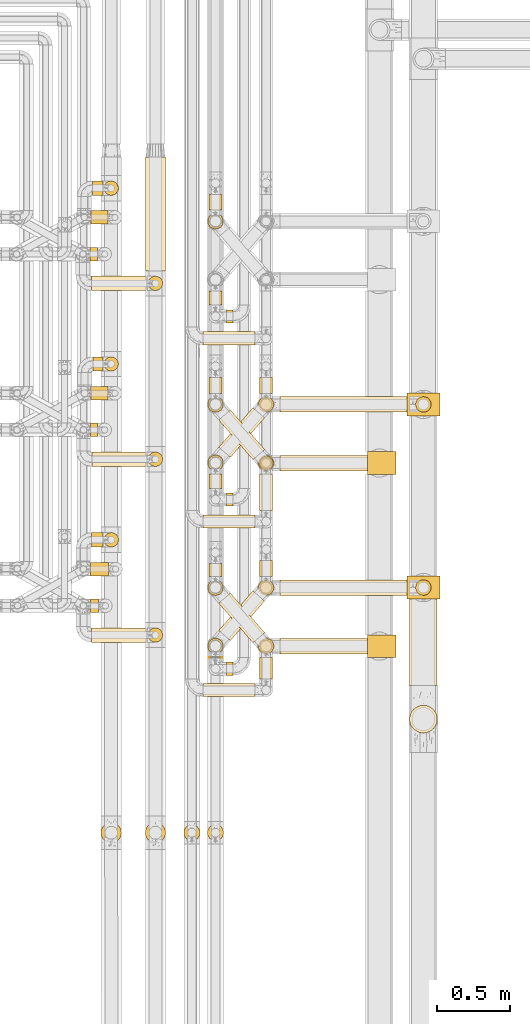
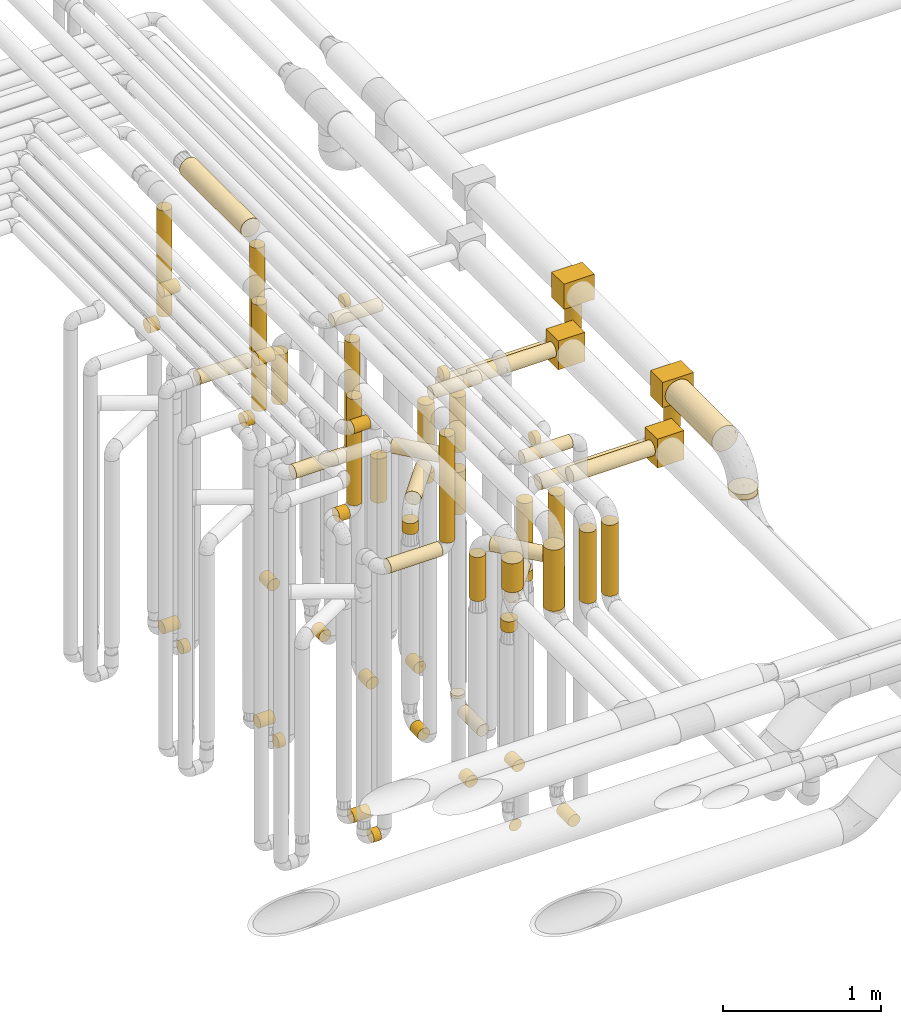
# One storey, part 12 of 824: 72 coverings.
"""IFC2X3 building model written with IfcOpenShell, lengths in millimetres."""

from ifc_helpers import new_model, entity, si_unit, converted_unit, derived_unit, direction, frame, origin, origin_2d_with_axis, place, context, subcontext, project, spatial, polyline, rectangle, circle, outline, extrude, element, save


model = new_model("IFC2X3")

# Units and contexts
model_context = context("Model", 3, precision=0.01, world=origin(), true_north=direction((6.12303176911189e-17, 1.0)))
body_context = subcontext(model_context, "Body", "Model", "MODEL_VIEW")
ifc_project = project(units=[si_unit("LENGTHUNIT", "METRE", prefix="MILLI"), si_unit("AREAUNIT", "SQUARE_METRE"), si_unit("VOLUMEUNIT", "CUBIC_METRE"), converted_unit("PLANEANGLEUNIT", "DEGREE", entity("IfcRatioMeasure", 0.0174532925199433), si_unit("PLANEANGLEUNIT", "RADIAN"), dimensions=[0, 0, 0, 0, 0, 0, 0]), si_unit("MASSUNIT", "GRAM", prefix="KILO"), derived_unit("MASSDENSITYUNIT", [(si_unit("MASSUNIT", "GRAM", prefix="KILO"), 1), (si_unit("LENGTHUNIT", "METRE"), -3)]), derived_unit("MOMENTOFINERTIAUNIT", [(si_unit("LENGTHUNIT", "METRE"), 4)]), si_unit("TIMEUNIT", "SECOND"), si_unit("FREQUENCYUNIT", "HERTZ"), si_unit("THERMODYNAMICTEMPERATUREUNIT", "DEGREE_CELSIUS"), derived_unit("THERMALTRANSMITTANCEUNIT", [(si_unit("MASSUNIT", "GRAM", prefix="KILO"), 1), (si_unit("THERMODYNAMICTEMPERATUREUNIT", "KELVIN"), -1), (si_unit("TIMEUNIT", "SECOND"), -3)]), derived_unit("VOLUMETRICFLOWRATEUNIT", [(si_unit("LENGTHUNIT", "METRE"), 3), (si_unit("TIMEUNIT", "SECOND"), -1)]), derived_unit("MASSFLOWRATEUNIT", [(si_unit("MASSUNIT", "GRAM", prefix="KILO"), 1), (si_unit("TIMEUNIT", "SECOND"), -1)]), derived_unit("ROTATIONALFREQUENCYUNIT", [(si_unit("TIMEUNIT", "SECOND"), -1)]), si_unit("ELECTRICCURRENTUNIT", "AMPERE"), si_unit("ELECTRICVOLTAGEUNIT", "VOLT"), si_unit("POWERUNIT", "WATT"), si_unit("FORCEUNIT", "NEWTON", prefix="KILO"), si_unit("ILLUMINANCEUNIT", "LUX"), si_unit("LUMINOUSFLUXUNIT", "LUMEN"), si_unit("LUMINOUSINTENSITYUNIT", "CANDELA"), derived_unit("USERDEFINED", [(si_unit("MASSUNIT", "GRAM", prefix="KILO"), -1), (si_unit("LENGTHUNIT", "METRE"), -2), (si_unit("TIMEUNIT", "SECOND"), 3), (si_unit("LUMINOUSFLUXUNIT", "LUMEN"), 1)]), derived_unit("LINEARVELOCITYUNIT", [(si_unit("LENGTHUNIT", "METRE"), 1), (si_unit("TIMEUNIT", "SECOND"), -1)]), si_unit("PRESSUREUNIT", "PASCAL"), derived_unit("USERDEFINED", [(si_unit("LENGTHUNIT", "METRE"), -2), (si_unit("MASSUNIT", "GRAM", prefix="KILO"), 1), (si_unit("TIMEUNIT", "SECOND"), -2)]), derived_unit("LINEARFORCEUNIT", [(si_unit("MASSUNIT", "GRAM", prefix="KILO"), 1), (si_unit("LENGTHUNIT", "METRE"), 1), (si_unit("TIMEUNIT", "SECOND"), -2), (si_unit("LENGTHUNIT", "METRE"), -1)]), derived_unit("PLANARFORCEUNIT", [(si_unit("MASSUNIT", "GRAM", prefix="KILO"), 1), (si_unit("LENGTHUNIT", "METRE"), 1), (si_unit("TIMEUNIT", "SECOND"), -2), (si_unit("LENGTHUNIT", "METRE"), -2)])], contexts=[model_context])

# Site, building, storey
site_placement = place(None, origin())
site = spatial("IfcSite", under=ifc_project, at=site_placement, CompositionType="ELEMENT")
building_placement = place(site_placement, origin())
building = spatial("IfcBuilding", under=site, at=building_placement, CompositionType="ELEMENT")
storey_placement = place(building_placement, frame((0.0, 0.0, 28200.0)))
storey = spatial("IfcBuildingStorey", under=building, at=storey_placement, CompositionType="ELEMENT", Elevation=28200.0)

# Coverings
covering_1_placement = place(storey_placement, frame((35784.85, 11758.46, 352.25)))
element("IfcCovering", 1, at=covering_1_placement, inside=storey, PredefinedType="INSULATION", context=body_context, shape_type="SweptSolid", body=[
    extrude(circle(Radius=46.15, at=origin_2d_with_axis()), frame((0.0, 47.75, 47.75), z_axis=(1.0, 0.0, 0.0), x_axis=(0.0, -1.0, 0.0)), (0.0, 0.0, 1.0), 110.194459668835),
])
covering_2_placement = place(storey_placement, frame((35776.05, 10558.46, 352.25)))
element("IfcCovering", 2, at=covering_2_placement, inside=storey, PredefinedType="INSULATION", context=body_context, shape_type="SweptSolid", body=[
    extrude(circle(Radius=46.15, at=origin_2d_with_axis()), frame((0.0, 47.75, 47.75), z_axis=(1.0, 0.0, 0.0), x_axis=(0.0, -1.0, 0.0)), (0.0, 0.0, 1.0), 124.000000000006),
])
covering_3_placement = place(storey_placement, frame((35847.22, 8736.54, 3214.0)))
element("IfcCovering", 3, at=covering_3_placement, inside=storey, PredefinedType="INSULATION", context=body_context, shape_type="SweptSolid", body=[
    extrude(circle(Radius=69.25, at=origin_2d_with_axis()), frame((70.85, 70.85, 0.0)), (0.0, 0.0, 1.0), 222.001032735806),
])
covering_4_placement = place(storey_placement, frame((35778.03, 11758.46, 3152.25)))
element("IfcCovering", 4, at=covering_4_placement, inside=storey, PredefinedType="INSULATION", context=body_context, shape_type="SweptSolid", body=[
    extrude(circle(Radius=46.15, at=origin_2d_with_axis()), frame((0.0, 47.75, 47.75), z_axis=(1.0, 0.0, 0.0), x_axis=(0.0, -1.0, 0.0)), (0.0, 0.0, 1.0), 117.013860378015),
])
covering_5_placement = place(storey_placement, frame((35785.05, 10755.61, 2549.4)))
element("IfcCovering", 5, at=covering_5_placement, inside=storey, PredefinedType="INSULATION", context=body_context, shape_type="SweptSolid", body=[
    extrude(circle(Radius=49.0, at=origin_2d_with_axis()), frame((0.0, 50.6, 50.6), z_axis=(1.0, -8.65020701261313e-08, 0.0), x_axis=(8.65020701261313e-08, 1.0, 0.0)), (0.0, 0.0, 1.0), 76.9274934935988),
])
covering_6_placement = place(storey_placement, frame((35868.38, 10755.61, 2657.0)))
element("IfcCovering", 6, at=covering_6_placement, inside=storey, PredefinedType="INSULATION", context=body_context, shape_type="SweptSolid", body=[
    extrude(circle(Radius=49.0, at=origin_2d_with_axis()), frame((50.6, 50.6, 0.0), z_axis=(0.0, 0.0, 1.0), x_axis=(-1.0, 0.0, 0.0)), (0.0, 0.0, 1.0), 820.000867851719),
])
covering_7_placement = place(storey_placement, frame((35793.85, 11955.49, 2549.4)))
element("IfcCovering", 7, at=covering_7_placement, inside=storey, PredefinedType="INSULATION", context=body_context, shape_type="SweptSolid", body=[
    extrude(circle(Radius=49.0, at=origin_2d_with_axis()), frame((0.0, 50.6, 50.6), z_axis=(1.0, -9.89978786120002e-08, 0.0), x_axis=(9.89978786120002e-08, 1.0, 0.0)), (0.0, 0.0, 1.0), 67.2173000496003),
])
covering_8_placement = place(storey_placement, frame((35867.47, 11955.49, 2657.0)))
element("IfcCovering", 8, at=covering_8_placement, inside=storey, PredefinedType="INSULATION", context=body_context, shape_type="SweptSolid", body=[
    extrude(circle(Radius=49.0, at=origin_2d_with_axis()), frame((50.6, 50.6, 0.0), z_axis=(0.0, 0.0, 1.0), x_axis=(-1.0, 0.0, 0.0)), (0.0, 0.0, 1.0), 820.000751547978),
])
covering_9_placement = place(storey_placement, frame((35791.24, 13155.49, 2549.4)))
element("IfcCovering", 9, at=covering_9_placement, inside=storey, PredefinedType="INSULATION", context=body_context, shape_type="SweptSolid", body=[
    extrude(circle(Radius=49.0, at=origin_2d_with_axis()), frame((0.0, 50.6, 50.6), z_axis=(1.0, -9.46746795771469e-08, -1.57223114131463e-05), x_axis=(9.46746795888483e-08, 1.0, 0.0)), (0.0, 0.0, 1.0), 70.2866927108459),
])
covering_10_placement = place(storey_placement, frame((35867.47, 13155.49, 2657.0)))
element("IfcCovering", 10, at=covering_10_placement, inside=storey, PredefinedType="INSULATION", context=body_context, shape_type="SweptSolid", body=[
    extrude(circle(Radius=49.0, at=origin_2d_with_axis()), frame((51.06, 50.6, 0.03), z_axis=(-0.000562863572107548, 0.0, 0.999999841592287), x_axis=(-0.999999841592287, 0.0, -0.000562863572107548)), (0.0, 0.0, 1.0), 819.96979389611),
])
covering_11_placement = place(storey_placement, frame((35778.03, 10558.46, 3352.25)))
element("IfcCovering", 11, at=covering_11_placement, inside=storey, PredefinedType="INSULATION", context=body_context, shape_type="SweptSolid", body=[
    extrude(circle(Radius=46.15, at=origin_2d_with_axis()), frame((0.0, 47.75, 47.75), z_axis=(1.0, 0.0, 0.0), x_axis=(0.0, -1.0, 0.0)), (0.0, 0.0, 1.0), 122.01386037804),
])
covering_12_placement = place(storey_placement, frame((35776.78, 11508.42, 352.25)))
element("IfcCovering", 12, at=covering_12_placement, inside=storey, PredefinedType="INSULATION", context=body_context, shape_type="SweptSolid", body=[
    extrude(circle(Radius=46.15, at=origin_2d_with_axis()), frame((0.0, 47.75, 47.75), z_axis=(1.0, 0.0, 0.0), x_axis=(0.0, -1.0, 0.0)), (0.0, 0.0, 1.0), 49.0000000000149),
])
covering_13_placement = place(storey_placement, frame((35776.05, 10308.42, 352.25)))
element("IfcCovering", 13, at=covering_13_placement, inside=storey, PredefinedType="INSULATION", context=body_context, shape_type="SweptSolid", body=[
    extrude(circle(Radius=46.15, at=origin_2d_with_axis()), frame((0.0, 47.75, 47.75), z_axis=(1.0, 0.0, 0.0), x_axis=(0.0, -1.0, 0.0)), (0.0, 0.0, 1.0), 54.7361396220235),
])
covering_14_placement = place(storey_placement, frame((36149.19, 8736.54, 2964.0)))
element("IfcCovering", 14, at=covering_14_placement, inside=storey, PredefinedType="INSULATION", context=body_context, shape_type="SweptSolid", body=[
    extrude(circle(Radius=69.25, at=origin_2d_with_axis()), frame((70.85, 70.85, 0.0), z_axis=(0.0, 0.0, 1.0), x_axis=(-1.0, 0.0, 0.0)), (0.0, 0.0, 1.0), 472.000402937329),
])
covering_15_placement = place(storey_placement, frame((35785.05, 10105.61, 2549.4)))
element("IfcCovering", 15, at=covering_15_placement, inside=storey, PredefinedType="INSULATION", context=body_context, shape_type="SweptSolid", body=[
    extrude(circle(Radius=49.0, at=origin_2d_with_axis()), frame((0.0, 50.6, 50.6), z_axis=(1.0, 0.0, 0.0), x_axis=(0.0, 1.0, 0.0)), (0.0, 0.0, 1.0), 377.986139621846),
])
covering_16_placement = place(storey_placement, frame((36169.44, 10105.61, 2657.0)))
element("IfcCovering", 16, at=covering_16_placement, inside=storey, PredefinedType="INSULATION", context=body_context, shape_type="SweptSolid", body=[
    extrude(outline(polyline([(-6.4, -48.58), (6.4, -48.58), (18.75, -45.27), (29.83, -38.87), (38.87, -29.83), (45.27, -18.75), (48.58, -6.4), (48.58, 6.4), (45.27, 18.75), (38.87, 29.83), (29.83, 38.87), (18.75, 45.27), (6.4, 48.58), (-6.4, 48.58), (-18.75, 45.27), (-29.83, 38.87), (-38.87, 29.83), (-45.27, 18.75), (-48.58, 6.4), (-48.58, -6.4), (-45.27, -18.75), (-38.87, -29.83), (-29.83, -38.87), (-18.75, -45.27), (-6.4, -48.58)])), frame((50.6, 50.6, 0.0), z_axis=(0.0, -8.1150678999826e-09, 1.0), x_axis=(0.991444861373812, 0.13052619222004, 1.05920046338611e-09)), (0.0, 0.0, 1.0), 820.000297304605),
])
covering_17_placement = place(storey_placement, frame((35785.78, 11305.49, 2549.4)))
element("IfcCovering", 17, at=covering_17_placement, inside=storey, PredefinedType="INSULATION", context=body_context, shape_type="SweptSolid", body=[
    extrude(circle(Radius=49.0, at=origin_2d_with_axis()), frame((0.0, 50.6, 50.6), z_axis=(1.0, 0.0, 0.0), x_axis=(0.0, 1.0, 0.0)), (0.0, 0.0, 1.0), 377.249999999815),
])
covering_18_placement = place(storey_placement, frame((36169.44, 11305.49, 2657.0)))
element("IfcCovering", 18, at=covering_18_placement, inside=storey, PredefinedType="INSULATION", context=body_context, shape_type="SweptSolid", body=[
    extrude(outline(polyline([(-6.4, -48.58), (6.4, -48.58), (18.75, -45.27), (29.83, -38.87), (38.87, -29.83), (45.27, -18.75), (48.58, -6.4), (48.58, 6.4), (45.27, 18.75), (38.87, 29.83), (29.83, 38.87), (18.75, 45.27), (6.4, 48.58), (-6.4, 48.58), (-18.75, 45.27), (-29.83, 38.87), (-38.87, 29.83), (-45.27, 18.75), (-48.58, 6.4), (-48.58, -6.4), (-45.27, -18.75), (-38.87, -29.83), (-29.83, -38.87), (-18.75, -45.27), (-6.4, -48.58)])), frame((50.6, 50.6, 0.0), z_axis=(0.0, -8.1150678999826e-09, 1.0), x_axis=(0.991444861373812, 0.13052619222004, 1.05920046338611e-09)), (0.0, 0.0, 1.0), 820.000187928744),
])
covering_19_placement = place(storey_placement, frame((35782.03, 12505.49, 2549.4)))
element("IfcCovering", 19, at=covering_19_placement, inside=storey, PredefinedType="INSULATION", context=body_context, shape_type="SweptSolid", body=[
    extrude(circle(Radius=49.0, at=origin_2d_with_axis()), frame((0.0, 50.6, 50.6), z_axis=(1.0, 0.0, 0.0), x_axis=(0.0, 1.0, 0.0)), (0.0, 0.0, 1.0), 380.999999885415),
])
covering_20_placement = place(storey_placement, frame((36169.44, 12505.49, 2657.0)))
element("IfcCovering", 20, at=covering_20_placement, inside=storey, PredefinedType="INSULATION", context=body_context, shape_type="SweptSolid", body=[
    extrude(outline(polyline([(-6.4, -48.58), (6.4, -48.58), (18.75, -45.27), (29.83, -38.87), (38.87, -29.83), (45.27, -18.75), (48.58, -6.4), (48.58, 6.4), (45.27, 18.75), (38.87, 29.83), (29.83, 38.87), (18.75, 45.27), (6.4, 48.58), (-6.4, 48.58), (-18.75, 45.27), (-29.83, 38.87), (-38.87, 29.83), (-45.27, 18.75), (-48.58, 6.4), (-48.58, -6.4), (-45.27, -18.75), (-38.87, -29.83), (-29.83, -38.87), (-18.75, -45.27), (-6.4, -48.58)])), frame((50.6, 50.6, 0.0), z_axis=(0.0, -8.1150678999826e-09, 1.0), x_axis=(0.991444861373812, 0.13052619222004, 1.05920046338611e-09)), (0.0, 0.0, 1.0), 820.000078541674),
])
covering_21_placement = place(storey_placement, frame((36149.19, 12642.08, 3479.15)))
element("IfcCovering", 21, at=covering_21_placement, inside=storey, PredefinedType="INSULATION", context=body_context, shape_type="SweptSolid", body=[
    extrude(circle(Radius=69.25, at=origin_2d_with_axis()), frame((70.85, 0.0, 70.85), z_axis=(0.0, 1.0, -9.11558732843855e-08), x_axis=(1.0, 0.0, 0.0)), (0.0, 0.0, 1.0), 775.61933044928),
])
covering_22_placement = place(storey_placement, frame((35773.03, 12708.42, 352.25)))
element("IfcCovering", 22, at=covering_22_placement, inside=storey, PredefinedType="INSULATION", context=body_context, shape_type="SweptSolid", body=[
    extrude(circle(Radius=46.15, at=origin_2d_with_axis()), frame((0.0, 47.75, 47.75), z_axis=(1.0, 0.0, 0.0), x_axis=(0.0, -1.0, 0.0)), (0.0, 0.0, 1.0), 52.7499998855939),
])
covering_23_placement = place(storey_placement, frame((35782.14, 12958.46, 352.25)))
element("IfcCovering", 23, at=covering_23_placement, inside=storey, PredefinedType="INSULATION", context=body_context, shape_type="SweptSolid", body=[
    extrude(circle(Radius=46.15, at=origin_2d_with_axis()), frame((0.0, 47.75, 47.75), z_axis=(1.0, 0.0, 0.0), x_axis=(0.0, -1.0, 0.0)), (0.0, 0.0, 1.0), 112.906910281965),
])
covering_24_placement = place(storey_placement, frame((35778.03, 12958.46, 2952.25)))
element("IfcCovering", 24, at=covering_24_placement, inside=storey, PredefinedType="INSULATION", context=body_context, shape_type="SweptSolid", body=[
    extrude(circle(Radius=46.15, at=origin_2d_with_axis()), frame((0.0, 47.75, 47.75), z_axis=(1.0, 0.0, 0.0), x_axis=(0.0, 1.0, 0.0)), (0.0, 0.0, 1.0), 117.013860377989),
])
covering_25_placement = place(storey_placement, frame((36546.03, 12134.58, 2953.4)))
element("IfcCovering", 25, at=covering_25_placement, inside=storey, PredefinedType="INSULATION", context=body_context, shape_type="SweptSolid", body=[
    extrude(circle(Radius=45.0, at=origin_2d_with_axis()), frame((0.0, 46.6, 46.6), z_axis=(1.0, 0.0, 0.0), x_axis=(0.0, 1.0, 0.0)), (0.0, 0.0, 1.0), 352.999982000022),
])
covering_26_placement = place(storey_placement, frame((36583.05, 13056.2, 353.4)))
element("IfcCovering", 26, at=covering_26_placement, inside=storey, PredefinedType="INSULATION", context=body_context, shape_type="SweptSolid", body=[
    extrude(circle(Radius=45.0, at=origin_2d_with_axis()), frame((46.6, 0.0, 46.6), z_axis=(0.0, 1.0, 0.0), x_axis=(1.0, 0.0, 0.0)), (0.0, 0.0, 1.0), 108.00000000001),
])
covering_27_placement = place(storey_placement, frame((36928.44, 11007.17, 353.4)))
element("IfcCovering", 27, at=covering_27_placement, inside=storey, PredefinedType="INSULATION", context=body_context, shape_type="SweptSolid", body=[
    extrude(circle(Radius=45.0, at=origin_2d_with_axis()), frame((46.6, 0.0, 46.6), z_axis=(0.0, 1.0, 0.0), x_axis=(-1.0, 0.0, 0.0)), (0.0, 0.0, 1.0), 247.028730184572),
])
covering_28_placement = place(storey_placement, frame((36928.44, 11283.61, 476.0)))
element("IfcCovering", 28, at=covering_28_placement, inside=storey, PredefinedType="INSULATION", context=body_context, shape_type="SweptSolid", body=[
    extrude(circle(Radius=45.0, at=origin_2d_with_axis()), frame((46.6, 46.6, 0.0), z_axis=(0.0, 0.0, 1.0), x_axis=(0.0, -1.0, 0.0)), (0.0, 0.0, 1.0), 23.9999845046597),
])
covering_29_placement = place(storey_placement, frame((36583.05, 11806.2, 353.4)))
element("IfcCovering", 29, at=covering_29_placement, inside=storey, PredefinedType="INSULATION", context=body_context, shape_type="SweptSolid", body=[
    extrude(circle(Radius=45.0, at=origin_2d_with_axis()), frame((46.6, 0.0, 46.6), z_axis=(0.0, 1.0, 0.0), x_axis=(1.0, 0.0, 0.0)), (0.0, 0.0, 1.0), 108.000000000014),
])
covering_30_placement = place(storey_placement, frame((36546.03, 10884.58, 3153.4)))
element("IfcCovering", 30, at=covering_30_placement, inside=storey, PredefinedType="INSULATION", context=body_context, shape_type="SweptSolid", body=[
    extrude(circle(Radius=45.0, at=origin_2d_with_axis()), frame((0.0, 46.6, 46.6), z_axis=(1.0, 0.0, 0.0), x_axis=(0.0, -1.0, 0.0)), (0.0, 0.0, 1.0), 352.999982000069),
])
covering_31_placement = place(storey_placement, frame((36928.44, 9857.02, 353.4)))
element("IfcCovering", 31, at=covering_31_placement, inside=storey, PredefinedType="INSULATION", context=body_context, shape_type="SweptSolid", body=[
    extrude(circle(Radius=45.0, at=origin_2d_with_axis()), frame((46.6, 0.0, 46.6), z_axis=(0.0, 1.0, 0.0), x_axis=(-1.0, 0.0, 0.0)), (0.0, 0.0, 1.0), 147.178757185185),
])
covering_32_placement = place(storey_placement, frame((36583.05, 10556.2, 353.4)))
element("IfcCovering", 32, at=covering_32_placement, inside=storey, PredefinedType="INSULATION", context=body_context, shape_type="SweptSolid", body=[
    extrude(circle(Radius=45.0, at=origin_2d_with_axis()), frame((46.6, 0.0, 46.6), z_axis=(0.0, 1.0, 0.0), x_axis=(1.0, 0.0, 0.0)), (0.0, 0.0, 1.0), 87.5194852591066),
])
covering_33_placement = place(storey_placement, frame((36546.03, 9734.43, 3353.4)))
element("IfcCovering", 33, at=covering_33_placement, inside=storey, PredefinedType="INSULATION", context=body_context, shape_type="SweptSolid", body=[
    extrude(circle(Radius=45.0, at=origin_2d_with_axis()), frame((0.0, 46.6, 46.6), z_axis=(1.0, 0.0, 0.0), x_axis=(0.0, -1.0, 0.0)), (0.0, 0.0, 1.0), 352.999982000091),
])
covering_34_placement = place(storey_placement, frame((36920.69, 11275.86, 2381.0)))
element("IfcCovering", 34, at=covering_34_placement, inside=storey, PredefinedType="INSULATION", context=body_context, shape_type="SweptSolid", body=[
    extrude(circle(Radius=52.75, at=origin_2d_with_axis()), frame((54.35, 54.35, 0.0)), (0.0, 0.0, 1.0), 423.9049607946),
])
covering_35_placement = place(storey_placement, frame((37070.03, 11275.86, 2845.56)))
element("IfcCovering", 35, at=covering_35_placement, inside=storey, PredefinedType="INSULATION", context=body_context, shape_type="SweptSolid", body=[
    extrude(circle(Radius=52.75, at=origin_2d_with_axis()), frame((0.0, 54.35, 54.35), z_axis=(1.0, 0.0, 3.16674345274106e-06), x_axis=(0.0, -1.0, 0.0)), (0.0, 0.0, 1.0), 595.765249593919),
])
covering_36_placement = place(storey_placement, frame((36575.3, 11675.86, 1870.0)))
element("IfcCovering", 36, at=covering_36_placement, inside=storey, PredefinedType="INSULATION", context=body_context, shape_type="SweptSolid", body=[
    extrude(circle(Radius=52.75, at=origin_2d_with_axis()), frame((54.35, 54.35, 0.0), z_axis=(0.0, 0.0, 1.0), x_axis=(-1.0, 0.0, 0.0)), (0.0, 0.0, 1.0), 340.000000000014),
])
covering_37_placement = place(storey_placement, frame((36650.22, 11351.67, 2250.65)))
element("IfcCovering", 37, at=covering_37_placement, inside=storey, PredefinedType="INSULATION", context=body_context, shape_type="SweptSolid", body=[
    extrude(circle(Radius=52.75, at=origin_2d_with_axis()), frame((41.52, 306.63, 54.35), z_axis=(0.65359148401651, -0.756847522306242, 0.0), x_axis=(0.756847522306242, 0.65359148401651, 0.0)), (0.0, 0.0, 1.0), 357.482862990724),
])
covering_38_placement = place(storey_placement, frame((36920.69, 11275.86, 1900.0)))
element("IfcCovering", 38, at=covering_38_placement, inside=storey, PredefinedType="INSULATION", context=body_context, shape_type="SweptSolid", body=[
    extrude(circle(Radius=52.75, at=origin_2d_with_axis()), frame((54.35, 54.35, 0.0)), (0.0, 0.0, 1.0), 328.999999999994),
])
covering_39_placement = place(storey_placement, frame((36575.3, 12925.86, 1870.0)))
element("IfcCovering", 39, at=covering_39_placement, inside=storey, PredefinedType="INSULATION", context=body_context, shape_type="SweptSolid", body=[
    extrude(circle(Radius=52.75, at=origin_2d_with_axis()), frame((54.35, 54.35, 0.0), z_axis=(0.0, 0.0, 1.0), x_axis=(-1.0, 0.0, 0.0)), (0.0, 0.0, 1.0), 384.999999999995),
])
covering_40_placement = place(storey_placement, frame((36920.69, 10025.86, 2381.0)))
element("IfcCovering", 40, at=covering_40_placement, inside=storey, PredefinedType="INSULATION", context=body_context, shape_type="SweptSolid", body=[
    extrude(circle(Radius=52.75, at=origin_2d_with_axis()), frame((54.35, 54.35, 0.0)), (0.0, 0.0, 1.0), 423.904960792813),
])
covering_41_placement = place(storey_placement, frame((37070.03, 10025.86, 2845.56)))
element("IfcCovering", 41, at=covering_41_placement, inside=storey, PredefinedType="INSULATION", context=body_context, shape_type="SweptSolid", body=[
    extrude(circle(Radius=52.75, at=origin_2d_with_axis()), frame((0.0, 54.35, 54.35), z_axis=(1.0, 0.0, 4.67529123142557e-06), x_axis=(0.0, -1.0, 0.0)), (0.0, 0.0, 1.0), 595.765844461526),
])
covering_42_placement = place(storey_placement, frame((36575.3, 10425.86, 1870.0)))
element("IfcCovering", 42, at=covering_42_placement, inside=storey, PredefinedType="INSULATION", context=body_context, shape_type="SweptSolid", body=[
    extrude(circle(Radius=52.75, at=origin_2d_with_axis()), frame((54.35, 54.35, 0.0), z_axis=(0.0, 0.0, 1.0), x_axis=(-1.0, 0.0, 0.0)), (0.0, 0.0, 1.0), 340.000000000014),
])
covering_43_placement = place(storey_placement, frame((36650.22, 10101.67, 2250.65)))
element("IfcCovering", 43, at=covering_43_placement, inside=storey, PredefinedType="INSULATION", context=body_context, shape_type="SweptSolid", body=[
    extrude(circle(Radius=52.75, at=origin_2d_with_axis()), frame((41.52, 306.63, 54.35), z_axis=(0.65359148401651, -0.756847522306242, 0.0), x_axis=(0.756847522306242, 0.65359148401651, 0.0)), (0.0, 0.0, 1.0), 357.482862990724),
])
covering_44_placement = place(storey_placement, frame((36920.69, 10025.86, 1900.0)))
element("IfcCovering", 44, at=covering_44_placement, inside=storey, PredefinedType="INSULATION", context=body_context, shape_type="SweptSolid", body=[
    extrude(circle(Radius=52.75, at=origin_2d_with_axis()), frame((54.35, 54.35, 0.0)), (0.0, 0.0, 1.0), 328.999999999994),
])
covering_45_placement = place(storey_placement, frame((36412.12, 8750.79, 2926.0)))
element("IfcCovering", 45, at=covering_45_placement, inside=storey, PredefinedType="INSULATION", context=body_context, shape_type="SweptSolid", body=[
    extrude(circle(Radius=55.0, at=origin_2d_with_axis()), frame((56.6, 56.6, 0.0), z_axis=(0.0, 0.0, 1.0), x_axis=(0.0, -1.0, 0.0)), (0.0, 0.0, 1.0), 548.000000000049),
])
covering_46_placement = place(storey_placement, frame((36573.05, 8750.79, 2926.0)))
element("IfcCovering", 46, at=covering_46_placement, inside=storey, PredefinedType="INSULATION", context=body_context, shape_type="SweptSolid", body=[
    extrude(circle(Radius=55.0, at=origin_2d_with_axis()), frame((56.6, 56.6, 0.0), z_axis=(0.0, 3.85413947979575e-08, 1.0), x_axis=(0.0, -1.0, 3.85413947979575e-08)), (0.0, 0.0, 1.0), 547.999328702734),
])
covering_47_placement = place(storey_placement, frame((37952.2, 9811.72, 2903.9)))
element("IfcCovering", 47, at=covering_47_placement, inside=storey, PredefinedType="INSULATION", context=body_context, shape_type="SweptSolid", body=[
    extrude(circle(Radius=94.5, at=origin_2d_with_axis()), frame((96.1, 0.0, 96.1), z_axis=(0.0, 1.0, 0.0), x_axis=(1.0, 0.0, 0.0)), (0.0, 0.0, 1.0), 590.986619555691),
])
covering_48_placement = place(storey_placement, frame((37952.2, 9486.62, 2729.0)))
element("IfcCovering", 48, at=covering_48_placement, inside=storey, PredefinedType="INSULATION", context=body_context, shape_type="SweptSolid", body=[
    extrude(circle(Radius=94.5, at=origin_2d_with_axis()), frame((96.1, 96.1, 0.0), z_axis=(0.0, 0.0, 1.0), x_axis=(-1.0, 0.0, 0.0)), (0.0, 0.0, 1.0), 42.0000000000208),
])
covering_49_placement = place(storey_placement, frame((36583.05, 12407.17, 353.4)))
element("IfcCovering", 49, at=covering_49_placement, inside=storey, PredefinedType="INSULATION", context=body_context, shape_type="SweptSolid", body=[
    extrude(circle(Radius=45.0, at=origin_2d_with_axis()), frame((46.6, 0.0, 46.6), z_axis=(0.0, 1.0, 0.0), x_axis=(-1.0, 0.0, 0.0)), (0.0, 0.0, 1.0), 97.9999910000113),
])
covering_50_placement = place(storey_placement, frame((36705.64, 12284.58, 2953.4)))
element("IfcCovering", 50, at=covering_50_placement, inside=storey, PredefinedType="INSULATION", context=body_context, shape_type="SweptSolid", body=[
    extrude(circle(Radius=45.0, at=origin_2d_with_axis()), frame((0.0, 46.6, 46.6), z_axis=(1.0, 0.0, 0.0), x_axis=(0.0, -1.0, 0.0)), (0.0, 0.0, 1.0), 43.3898252877541),
])
covering_51_placement = place(storey_placement, frame((36928.44, 11806.2, 353.4)))
element("IfcCovering", 51, at=covering_51_placement, inside=storey, PredefinedType="INSULATION", context=body_context, shape_type="SweptSolid", body=[
    extrude(circle(Radius=45.0, at=origin_2d_with_axis()), frame((46.6, 0.0, 46.6), z_axis=(0.0, 1.0, 0.0), x_axis=(1.0, 0.0, 0.0)), (0.0, 0.0, 1.0), 108.000000000017),
])
covering_52_placement = place(storey_placement, frame((36920.69, 11675.86, 2126.0)))
element("IfcCovering", 52, at=covering_52_placement, inside=storey, PredefinedType="INSULATION", context=body_context, shape_type="SweptSolid", body=[
    extrude(circle(Radius=52.75, at=origin_2d_with_axis()), frame((54.35, 54.35, 0.0)), (0.0, 0.0, 1.0), 378.999999999992),
])
covering_53_placement = place(storey_placement, frame((36583.05, 11157.17, 353.4)))
element("IfcCovering", 53, at=covering_53_placement, inside=storey, PredefinedType="INSULATION", context=body_context, shape_type="SweptSolid", body=[
    extrude(circle(Radius=45.0, at=origin_2d_with_axis()), frame((46.6, 0.0, 46.6), z_axis=(0.0, 1.0, 0.0), x_axis=(-1.0, 0.0, 0.0)), (0.0, 0.0, 1.0), 98.4177180789936),
])
covering_54_placement = place(storey_placement, frame((36705.64, 11034.58, 3153.4)))
element("IfcCovering", 54, at=covering_54_placement, inside=storey, PredefinedType="INSULATION", context=body_context, shape_type="SweptSolid", body=[
    extrude(circle(Radius=45.0, at=origin_2d_with_axis()), frame((0.0, 46.6, 46.6), z_axis=(1.0, 0.0, 0.0), x_axis=(0.0, 1.0, 0.0)), (0.0, 0.0, 1.0), 43.3898252877585),
])
covering_55_placement = place(storey_placement, frame((36928.44, 10556.2, 353.4)))
element("IfcCovering", 55, at=covering_55_placement, inside=storey, PredefinedType="INSULATION", context=body_context, shape_type="SweptSolid", body=[
    extrude(circle(Radius=45.0, at=origin_2d_with_axis()), frame((46.6, 0.0, 46.6), z_axis=(0.0, 1.0, 0.0), x_axis=(1.0, 0.0, 0.0)), (0.0, 0.0, 1.0), 108.000000000017),
])
covering_56_placement = place(storey_placement, frame((36583.05, 10002.17, 353.4)))
element("IfcCovering", 56, at=covering_56_placement, inside=storey, PredefinedType="INSULATION", context=body_context, shape_type="SweptSolid", body=[
    extrude(circle(Radius=45.0, at=origin_2d_with_axis()), frame((46.6, 0.0, 46.6), z_axis=(0.0, 1.0, 0.0), x_axis=(-1.0, 0.0, 0.0)), (0.0, 0.0, 1.0), 3.41771807897185),
])
covering_57_placement = place(storey_placement, frame((36705.64, 9879.58, 3353.4)))
element("IfcCovering", 57, at=covering_57_placement, inside=storey, PredefinedType="INSULATION", context=body_context, shape_type="SweptSolid", body=[
    extrude(circle(Radius=45.0, at=origin_2d_with_axis()), frame((0.0, 46.6, 46.6), z_axis=(1.0, 0.0, 0.0), x_axis=(0.0, -1.0, 0.0)), (0.0, 0.0, 1.0), 43.3898252877585),
])
covering_58_placement = place(storey_placement, frame((37070.03, 11675.86, 2545.65)))
element("IfcCovering", 58, at=covering_58_placement, inside=storey, PredefinedType="INSULATION", context=body_context, shape_type="SweptSolid", body=[
    extrude(circle(Radius=52.75, at=origin_2d_with_axis()), frame((0.0, 54.35, 54.35), z_axis=(1.0, 0.0, 0.0), x_axis=(0.0, 1.0, 0.0)), (0.0, 0.0, 1.0), 883.26568841584),
])
covering_59_placement = place(storey_placement, frame((36575.3, 11277.25, 1870.0)))
element("IfcCovering", 59, at=covering_59_placement, inside=storey, PredefinedType="INSULATION", context=body_context, shape_type="SweptSolid", body=[
    extrude(circle(Radius=52.75, at=origin_2d_with_axis()), frame((54.35, 54.35, 0.0), z_axis=(0.0, 0.0, 1.0), x_axis=(-1.0, 0.0, 0.0)), (0.0, 0.0, 1.0), 84.9999999999937),
])
covering_60_placement = place(storey_placement, frame((36650.22, 11367.42, 1995.65)))
element("IfcCovering", 60, at=covering_60_placement, inside=storey, PredefinedType="INSULATION", context=body_context, shape_type="SweptSolid", body=[
    extrude(circle(Radius=52.75, at=origin_2d_with_axis()), frame((41.52, 36.07, 54.35), z_axis=(0.653617255256319, 0.756825266247894, 0.0), x_axis=(-0.756825266247894, 0.653617255256319, 0.0)), (0.0, 0.0, 1.0), 356.436515701913),
])
covering_61_placement = place(storey_placement, frame((36920.69, 11675.86, 1900.0)))
element("IfcCovering", 61, at=covering_61_placement, inside=storey, PredefinedType="INSULATION", context=body_context, shape_type="SweptSolid", body=[
    extrude(circle(Radius=52.75, at=origin_2d_with_axis()), frame((54.35, 54.35, 0.0)), (0.0, 0.0, 1.0), 74.0000000000048),
])
covering_62_placement = place(storey_placement, frame((36920.69, 10425.86, 2126.0)))
element("IfcCovering", 62, at=covering_62_placement, inside=storey, PredefinedType="INSULATION", context=body_context, shape_type="SweptSolid", body=[
    extrude(circle(Radius=52.75, at=origin_2d_with_axis()), frame((54.35, 54.35, 0.0)), (0.0, 0.0, 1.0), 379.0),
])
covering_63_placement = place(storey_placement, frame((37070.03, 10425.86, 2545.65)))
element("IfcCovering", 63, at=covering_63_placement, inside=storey, PredefinedType="INSULATION", context=body_context, shape_type="SweptSolid", body=[
    extrude(circle(Radius=52.75, at=origin_2d_with_axis()), frame((0.0, 54.35, 54.35), z_axis=(1.0, 0.0, 0.0), x_axis=(0.0, 1.0, 0.0)), (0.0, 0.0, 1.0), 883.26568841584),
])
covering_64_placement = place(storey_placement, frame((36575.3, 10027.25, 1870.0)))
element("IfcCovering", 64, at=covering_64_placement, inside=storey, PredefinedType="INSULATION", context=body_context, shape_type="SweptSolid", body=[
    extrude(circle(Radius=52.75, at=origin_2d_with_axis()), frame((54.35, 54.35, 0.0), z_axis=(0.0, 0.0, 1.0), x_axis=(-1.0, 0.0, 0.0)), (0.0, 0.0, 1.0), 84.9999999999937),
])
covering_65_placement = place(storey_placement, frame((36650.22, 10117.42, 1995.65)))
element("IfcCovering", 65, at=covering_65_placement, inside=storey, PredefinedType="INSULATION", context=body_context, shape_type="SweptSolid", body=[
    extrude(circle(Radius=52.75, at=origin_2d_with_axis()), frame((41.52, 36.07, 54.35), z_axis=(0.653617255256319, 0.756825266247894, 0.0), x_axis=(-0.756825266247894, 0.653617255256319, 0.0)), (0.0, 0.0, 1.0), 356.436515701913),
])
covering_66_placement = place(storey_placement, frame((36920.69, 10425.86, 1900.0)))
element("IfcCovering", 66, at=covering_66_placement, inside=storey, PredefinedType="INSULATION", context=body_context, shape_type="SweptSolid", body=[
    extrude(circle(Radius=52.75, at=origin_2d_with_axis()), frame((54.35, 54.35, 0.0)), (0.0, 0.0, 1.0), 74.0000000000048),
])
covering_67_placement = place(storey_placement, frame((37993.7, 10425.61, 2695.0)))
element("IfcCovering", 67, at=covering_67_placement, inside=storey, PredefinedType="INSULATION", context=body_context, shape_type="SweptSolid", body=[
    extrude(circle(Radius=53.0, at=origin_2d_with_axis()), frame((54.6, 54.6, 0.0), z_axis=(0.0, 0.0, 1.0), x_axis=(0.0, -1.0, 0.0)), (0.0, 0.0, 1.0), 222.500000000001),
])
covering_68_placement = place(storey_placement, frame((37936.42, 10402.7, 2917.5)))
element("IfcCovering", 68, at=covering_68_placement, inside=storey, PredefinedType="INSULATION", context=body_context, shape_type="SweptSolid", body=[
    extrude(rectangle(XDim=154.999999999995, YDim=223.750000000001, at=origin_2d_with_axis()), frame((111.87, 77.5, 0.0), z_axis=(0.0, 0.0, 1.0), x_axis=(0.0, 1.0, 0.0)), (0.0, 0.0, 1.0), 194.37500000001),
])
covering_69_placement = place(storey_placement, frame((37993.7, 11675.61, 2695.0)))
element("IfcCovering", 69, at=covering_69_placement, inside=storey, PredefinedType="INSULATION", context=body_context, shape_type="SweptSolid", body=[
    extrude(circle(Radius=53.0, at=origin_2d_with_axis()), frame((54.6, 54.6, 0.0), z_axis=(0.0, 0.0, 1.0), x_axis=(0.0, -1.0, 0.0)), (0.0, 0.0, 1.0), 222.499999999993),
])
covering_70_placement = place(storey_placement, frame((37936.42, 11652.7, 2917.5)))
element("IfcCovering", 70, at=covering_70_placement, inside=storey, PredefinedType="INSULATION", context=body_context, shape_type="SweptSolid", body=[
    extrude(rectangle(XDim=154.999999999995, YDim=223.750000000001, at=origin_2d_with_axis()), frame((111.87, 77.5, 0.0), z_axis=(0.0, 0.0, 1.0), x_axis=(0.0, -1.0, 0.0)), (0.0, 0.0, 1.0), 194.37500000001),
])
covering_71_placement = place(storey_placement, frame((37665.8, 11252.7, 2788.03)))
element("IfcCovering", 71, at=covering_71_placement, inside=storey, PredefinedType="INSULATION", context=body_context, shape_type="SweptSolid", body=[
    extrude(rectangle(XDim=155.000000000036, YDim=194.37500000001, at=origin_2d_with_axis()), frame((97.19, 77.5, 0.0), z_axis=(0.0, 0.0, 1.0), x_axis=(0.0, -1.0, 0.0)), (0.0, 0.0, 1.0), 223.750137188377),
])
covering_72_placement = place(storey_placement, frame((37665.8, 10002.7, 2788.03)))
element("IfcCovering", 72, at=covering_72_placement, inside=storey, PredefinedType="INSULATION", context=body_context, shape_type="SweptSolid", body=[
    extrude(rectangle(XDim=155.000000000038, YDim=194.37500000001, at=origin_2d_with_axis()), frame((97.19, 77.5, 0.0), z_axis=(0.0, 0.0, 1.0), x_axis=(0.0, -1.0, 0.0)), (0.0, 0.0, 1.0), 223.750137188377),
])

save(model, "model.ifc")
